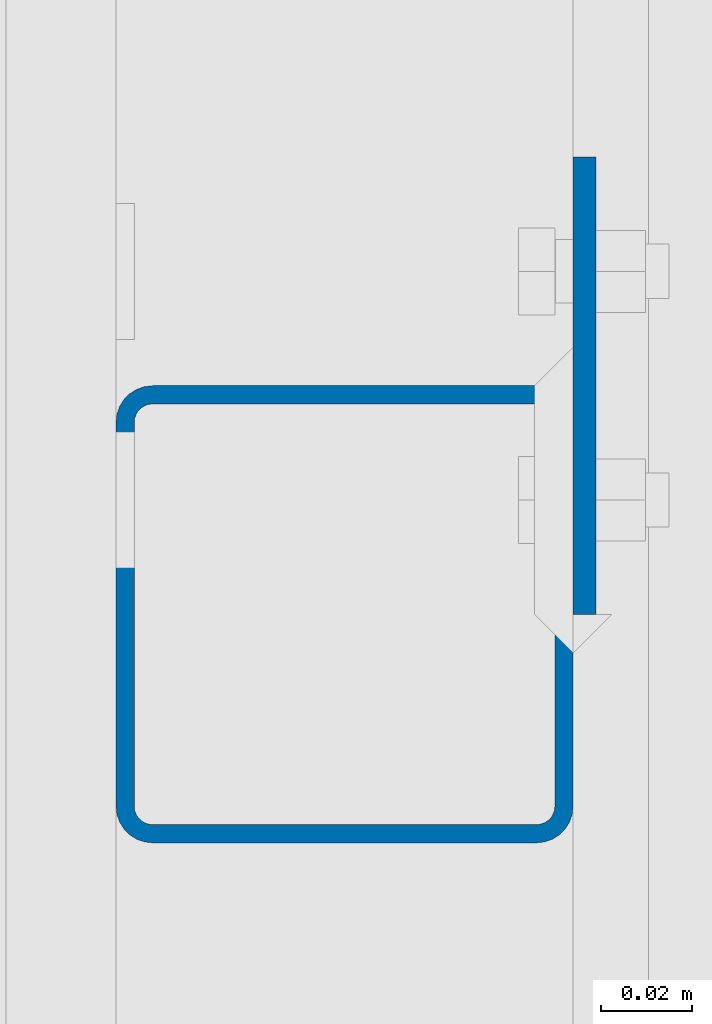
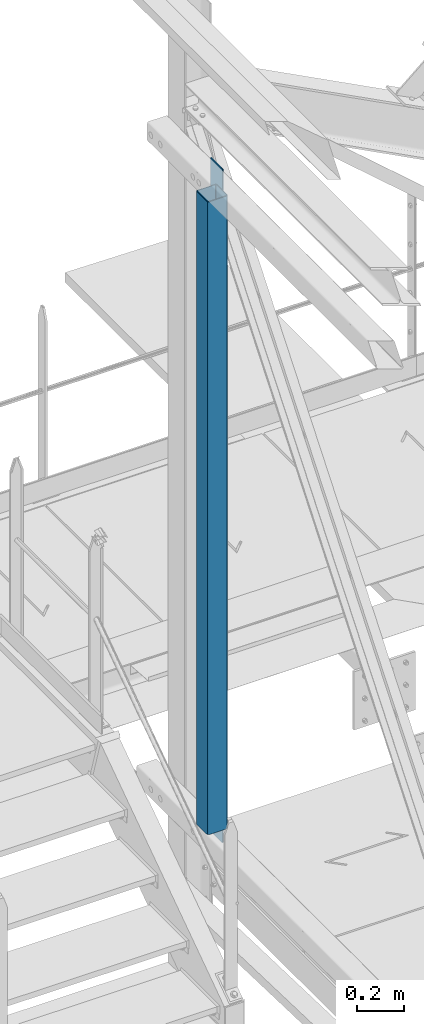
# One storey, part 7 of 496: 2 columns, 1 element without a shape of its own.
"""IFC2X3 building model written with IfcOpenShell, lengths in millimetres."""

from ifc_helpers import new_model, si_unit, frame, origin_with_axes, origin_2d_with_axis, place, context, subcontext, project, spatial, rectangle, hollow_rectangle, extrude, material, type_object, element, aggregate, save


model = new_model("IFC2X3")

# Units and contexts
model_context = context("Model", 3, precision=1e-05, world=origin_with_axes())
body_context = subcontext(model_context, "Body", "Model", "MODEL_VIEW")
ifc_project = project(units=[si_unit("LENGTHUNIT", "METRE", prefix="MILLI"), si_unit("AREAUNIT", "SQUARE_METRE"), si_unit("VOLUMEUNIT", "CUBIC_METRE"), si_unit("MASSUNIT", "GRAM", prefix="KILO"), si_unit("TIMEUNIT", "SECOND"), si_unit("PLANEANGLEUNIT", "RADIAN"), si_unit("SOLIDANGLEUNIT", "STERADIAN"), si_unit("THERMODYNAMICTEMPERATUREUNIT", "DEGREE_CELSIUS"), si_unit("LUMINOUSINTENSITYUNIT", "LUMEN")], contexts=[model_context])

# Site, building, storey
site_placement = place(None, origin_with_axes())
site = spatial("IfcSite", under=ifc_project, at=site_placement, CompositionType="ELEMENT")
building_placement = place(site_placement, origin_with_axes())
building = spatial("IfcBuilding", under=site, at=building_placement, Name="Undefined", CompositionType="ELEMENT")
storey_placement = place(building_placement, origin_with_axes())
storey = spatial("IfcBuildingStorey", under=building, at=storey_placement, Name="Undefined", CompositionType="ELEMENT", Elevation=0.0)

# Assembly, columns
assembly_placement = place(storey_placement, origin_with_axes())
assembly = element("IfcElementAssembly", 1, at=assembly_placement, inside=storey, Name="MONTANT", AssemblyPlace="NOTDEFINED", PredefinedType="NOTDEFINED")
ifc_material = material(Name="Undefined/S235-E24")
column_type_1 = type_object("IfcColumnType", PredefinedType="NOTDEFINED")
column_1_placement = place(assembly_placement, frame((12563.5000106229, 14809.9999987907, 8555.00000000001), z_axis=(0.0, 0.0, 1.0), x_axis=(0.0, 1.0, 0.0)))
column_1 = element("IfcColumn", 2, at=column_1_placement, type_object=column_type_1, material=ifc_material, Name="MONTANT", context=body_context, shape_type="SweptSolid", body=[
    extrude(hollow_rectangle(XDim=100.0, YDim=100.0, WallThickness=4.0, InnerFilletRadius=4.0, OuterFilletRadius=8.0, at=origin_2d_with_axis()), frame((0.0, 0.0, 3260.0), z_axis=(0.0, 0.0, -1.0), x_axis=(0.0, 1.0, 0.0)), (0.0, 0.0, 1.0), 3260.0),
])
column_type_2 = type_object("IfcColumnType", PredefinedType="NOTDEFINED")
column_2_placement = place(assembly_placement, frame((12616.0000013656, 14859.9999987907, 8450.0), z_axis=(0.0, 0.0, 1.0), x_axis=(0.0, 1.0, 0.0)))
column_2 = element("IfcColumn", 3, at=column_2_placement, type_object=column_type_2, material=ifc_material, context=body_context, shape_type="SweptSolid", body=[
    extrude(rectangle(XDim=5.0, YDim=100.0, at=origin_2d_with_axis()), frame((0.0, 0.0, 3470.0), z_axis=(0.0, 0.0, -1.0), x_axis=(0.0, 1.0, 0.0)), (0.0, 0.0, 1.0), 3470.0),
])
aggregate(assembly, [column_2, column_1])

save(model, "model.ifc")
